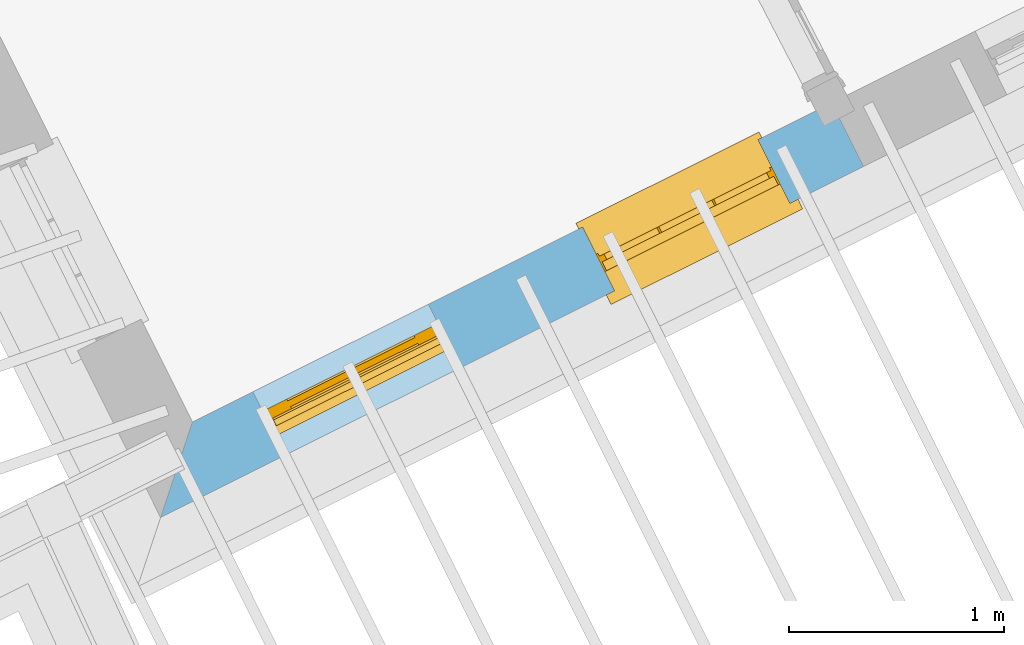
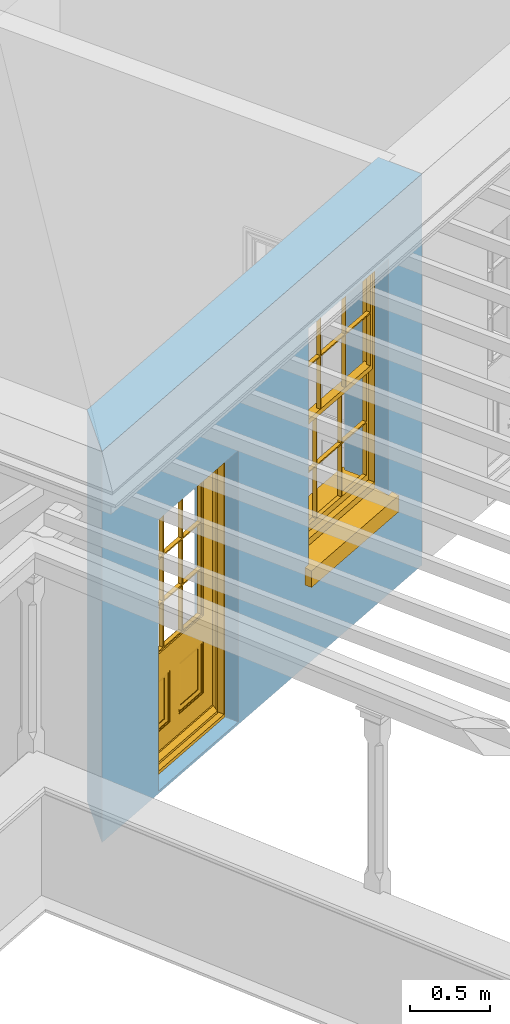
# One storey, part 2 of 7: 1 door, 1 window, 2 openings, plus 1 element that does not belong to this part.
"""IFC2X3 building model written with IfcOpenShell, lengths in metres."""

from ifc_helpers import new_model, si_unit, frame, origin, place, context, subcontext, project, spatial, polyline, outline, extrude, faceted_brep, material, layer, layer_set, layer_usage, element, fill, save


model = new_model("IFC2X3")

# Units and contexts
model_context = context("Model", 3, world=origin())
body_context = subcontext(model_context, "Body", "Model", "MODEL_VIEW")
ifc_project = project(units=[si_unit("PLANEANGLEUNIT", "RADIAN"), si_unit("MASSUNIT", "GRAM", prefix="KILO"), si_unit("FORCEUNIT", "NEWTON", prefix="KILO"), si_unit("LENGTHUNIT", "METRE")], contexts=[model_context])

# Site, building, storey
site_placement = place(None, origin())
site = spatial("IfcSite", under=ifc_project, at=site_placement, CompositionType="ELEMENT")
building_placement = place(None, origin())
building = spatial("IfcBuilding", under=site, at=building_placement, Name="Building plot-8", CompositionType="ELEMENT")
storey_placement = place(None, frame((0.0, 0.0, 6.3)))
storey = spatial("IfcBuildingStorey", under=building, at=storey_placement, Name="Floor 2", CompositionType="ELEMENT", Elevation=6.3)

# Wall, openings, door, window
ifc_material = material(Name="Masonry")
ifc_layer = layer(ifc_material, 0.33, ventilated=False)
ifc_layer_set = layer_set([ifc_layer], Name="My Wall")
ifc_layer_usage = layer_usage(ifc_layer_set, "AXIS2", "NEGATIVE", 0.08)
wall_placement = place(storey_placement, origin())
wall = element("IfcWallStandardCase", 1, at=wall_placement, inside=storey, material=ifc_layer_usage, Name="exterior", context=body_context, shape_type="SweptSolid", body=[
    extrude(outline(polyline([(24.4433832878594, 13.4608989674064), (24.2955349008038, 13.0182468981183), (27.5576474990724, 14.6468363352565), (27.4102456579562, 14.9420865634283), (24.4433832878594, 13.4608989674064)])), origin(), (0.0, 0.0, 1.0), 3.0),
])
opening_1_placement = place(storey_placement, frame((0.0, 0.0, 0.0199999999999996)))
opening_1 = element("IfcOpeningElement", 2, at=opening_1_placement, cuts=wall, Name="Opening", ObjectType="Opening", context=body_context, shape_type="SweptSolid", body=[
    extrude(outline(polyline([(24.8717314260195, 13.3059094316495), (25.685906297645, 13.7123811753337), (25.5385044565287, 14.0076314035056), (24.7243295849033, 13.6011596598214), (24.8717314260195, 13.3059094316495)])), origin(), (0.0, 0.0, 1.0), 2.08),
])
opening_2_placement = place(storey_placement, frame((0.0, 0.0, 0.75)))
opening_2 = element("IfcOpeningElement", 3, at=opening_2_placement, cuts=wall, Name="Opening", ObjectType="Opening", context=body_context, shape_type="SweptSolid", body=[
    extrude(outline(polyline([(26.4016644265464, 14.0697189719792), (27.2158392981719, 14.4761907156634), (27.0684374570556, 14.7714409438353), (26.2542625854302, 14.3649692001511), (26.4016644265464, 14.0697189719792)])), origin(), (0.0, 0.0, 1.0), 1.82),
])
door_placement = place(storey_placement, frame((24.7600633645678, 13.5295838469312, 0.0199999999999996), z_axis=(0.0, 0.0, 1.0), x_axis=(0.814174871625436, 0.406471743684232, 0.0)))
door = element("IfcDoor", 4, at=door_placement, inside=storey, Name="circulation outside door", OverallHeight=2.08, OverallWidth=0.91, context=body_context, shape_type="Brep", held_by="IfcProductRepresentation", body=[
    faceted_brep([(0.545, -0.055, 0.265), (0.745, -0.055, 0.265), (0.745, -0.05, 0.265), (0.545, -0.05, 0.265), (0.745, -0.05, 0.58), (0.545, -0.05, 0.58), (0.545, -0.055, 0.58), (0.515, -0.06, 0.235), (0.775, -0.06, 0.235), (0.745, -0.055, 0.58), (0.515, -0.06, 0.61), (0.515, -0.065, 0.235), (0.775, -0.065, 0.235), (0.775, -0.06, 0.61), (0.515, -0.065, 0.61), (0.785, -0.065, 0.225), (0.505, -0.065, 0.225), (0.775, -0.065, 0.61), (0.505, -0.065, 0.62), (0.785, -0.065, 0.62), (0.505, -0.07, 0.225), (0.785, -0.07, 0.225), (0.505, -0.07, 0.62), (0.785, -0.07, 0.62), (0.883, -0.07, 0.075), (0.898, -0.07, 0.075), (0.405, -0.07, 0.62), (0.405, -0.07, 0.225), (0.027, -0.07, 0.075), (0.785, -0.07, 0.82), (0.125, -0.07, 0.82), (0.405, -0.065, 0.62), (0.405, -0.065, 0.225), (0.898, -0.07, 2.068), (0.027, -0.08, 0.075), (0.883, -0.08, 0.075), (0.125, -0.07, 0.225), (0.012, -0.07, 0.075), (0.785, -0.06, 0.82), (0.125, -0.06, 0.82), (0.125, -0.07, 0.62), (0.125, -0.065, 0.62), (0.395, -0.065, 0.61), (0.395, -0.065, 0.235), (0.125, -0.065, 0.225), (0.785, -0.07, 1.895), (0.027, -0.11, 0.045), (0.883, -0.11, 0.045), (0.558333, -0.06, 0.83), (0.351667, -0.06, 0.83), (0.125, -0.07, 1.895), (0.125, -0.06, 1.895), (0.785, -0.06, 1.895), (0.012, -0.07, 2.068), (0.135, -0.065, 0.61), (0.395, -0.06, 0.61), (0.395, -0.06, 0.235), (0.135, -0.065, 0.235), (0.027, -0.11, 0.027), (0.883, -0.11, 0.027), (0.568333, -0.06, 0.83), (0.558333, -0.03, 0.83), (0.351667, -0.03, 0.83), (0.341667, -0.06, 0.83), (0.135, -0.06, 1.185), (0.135, -0.06, 1.53), (0.775, -0.06, 1.53), (0.775, -0.06, 1.185), (0.135, -0.06, 0.61), (0.365, -0.055, 0.58), (0.365, -0.055, 0.265), (0.135, -0.06, 0.235), (0.568333, -0.06, 1.175), (0.558333, -0.06, 1.175), (0.775, -0.06, 0.83), (0.558333, -0.03, 1.175), (0.785, -0.03, 0.82), (0.125, -0.03, 0.82), (0.351667, -0.03, 1.175), (0.351667, -0.06, 1.175), (0.341667, -0.06, 1.175), (0.135, -0.06, 0.83), (0.135, -0.06, 1.175), (0.135, -0.03, 1.185), (0.135, -0.03, 1.53), (0.135, -0.06, 1.54), (0.351667, -0.06, 1.885), (0.558333, -0.06, 1.885), (0.775, -0.03, 1.53), (0.775, -0.03, 1.185), (0.775, -0.06, 1.175), (0.775, -0.06, 1.54), (0.165, -0.055, 0.58), (0.365, -0.05, 0.58), (0.365, -0.05, 0.265), (0.165, -0.055, 0.265), (0.568333, -0.03, 0.83), (0.568333, -0.03, 1.175), (0.568333, -0.06, 1.185), (0.558333, -0.06, 1.185), (0.775, -0.03, 0.83), (0.785, -0.02, 0.82), (0.125, -0.02, 0.82), (0.341667, -0.03, 0.83), (0.341667, -0.03, 1.175), (0.351667, -0.06, 1.185), (0.341667, -0.06, 1.185), (0.135, -0.03, 0.83), (0.341667, -0.03, 1.185), (0.125, -0.03, 1.895), (0.341667, -0.03, 1.53), (0.341667, -0.06, 1.53), (0.135, -0.06, 1.885), (0.341667, -0.06, 1.54), (0.341667, -0.06, 1.885), (0.558333, -0.03, 1.885), (0.351667, -0.03, 1.885), (0.568333, -0.06, 1.885), (0.785, -0.03, 1.895), (0.568333, -0.03, 1.185), (0.568333, -0.06, 1.53), (0.568333, -0.03, 1.53), (0.568333, -0.06, 1.54), (0.775, -0.06, 1.885), (0.165, -0.05, 0.58), (0.165, -0.05, 0.265), (0.775, -0.03, 1.175), (0.558333, -0.06, 1.53), (0.351667, -0.03, 1.185), (0.558333, -0.03, 1.185), (0.505, -0.02, 0.62), (0.405, -0.02, 0.62), (0.125, -0.02, 1.895), (0.785, -0.02, 1.895), (0.351667, -0.06, 1.53), (0.135, -0.03, 1.175), (0.135, -0.03, 1.54), (0.341667, -0.03, 1.54), (0.135, -0.03, 1.885), (0.351667, -0.06, 1.54), (0.558333, -0.03, 1.54), (0.558333, -0.06, 1.54), (0.351667, -0.03, 1.54), (0.775, -0.03, 1.54), (0.568333, -0.03, 1.54), (0.775, -0.03, 1.885), (0.558333, -0.03, 1.53), (0.405, -0.02, 0.225), (0.505, -0.02, 0.225), (0.125, -0.02, 0.62), (0.785, -0.02, 0.62), (0.012, -0.02, 2.068), (0.898, -0.02, 2.068), (0.351667, -0.03, 1.53), (0.341667, -0.03, 1.885), (0.568333, -0.03, 1.885), (0.405, -0.025, 0.225), (0.405, -0.025, 0.62), (0.505, -0.025, 0.62), (0.505, -0.025, 0.225), (0.898, -0.02, 0.027), (0.012, -0.02, 0.027), (0.125, -0.025, 0.62), (0.785, -0.025, 0.62), (0.395, -0.025, 0.235), (0.395, -0.025, 0.61), (0.125, -0.02, 0.225), (0.125, -0.025, 0.225), (0.515, -0.025, 0.61), (0.515, -0.025, 0.235), (0.785, -0.02, 0.225), (0.785, -0.025, 0.225), (0.135, -0.025, 0.61), (0.775, -0.025, 0.61), (0.135, -0.025, 0.235), (0.395, -0.03, 0.235), (0.395, -0.03, 0.61), (0.515, -0.03, 0.61), (0.515, -0.03, 0.235), (0.775, -0.025, 0.235), (0.135, -0.03, 0.61), (0.775, -0.03, 0.61), (0.135, -0.03, 0.235), (0.365, -0.035, 0.265), (0.365, -0.035, 0.58), (0.545, -0.035, 0.58), (0.545, -0.035, 0.265), (0.775, -0.03, 0.235), (0.165, -0.035, 0.58), (0.745, -0.035, 0.58), (0.165, -0.035, 0.265), (0.365, -0.04, 0.58), (0.365, -0.04, 0.265), (0.545, -0.04, 0.58), (0.545, -0.04, 0.265), (0.745, -0.035, 0.265), (0.165, -0.04, 0.58), (0.745, -0.04, 0.58), (0.165, -0.04, 0.265), (0.745, -0.04, 0.265), (0.885, -0.072, 0.025), (0.025, -0.072, 0.025), (0.025, -0.1, 0.025), (0.885, -0.1, 0.025), (0.9, -0.02, 0.025), (0.01, -0.02, 0.025), (0.9, -0.072, 0.025), (0.91, -0.02, 0.0), (0.0, -0.02, 0.0), (0.01, -0.072, 0.025), (0.9, -0.072, 2.07), (0.9, -0.02, 2.07), (0.885, -0.072, 2.055), (0.91, -0.02, 2.08), (0.01, -0.02, 2.07), (0.0, -0.02, 2.08), (0.01, -0.072, 2.07), (0.025, -0.072, 2.055), (0.0, -0.15, 2.08), (0.91, -0.15, 2.08), (0.01, -0.15, 2.07), (0.9, -0.15, 2.07), (0.01, -0.1, 2.07), (0.9, -0.1, 2.07), (0.0, -0.15, 0.0), (0.91, -0.15, 0.0), (0.01, -0.15, 0.025), (0.9, -0.15, 0.025), (0.01, -0.1, 0.025), (0.025, -0.1, 2.055), (0.9, -0.1, 0.025), (0.885, -0.1, 2.055), (0.898, -0.07, 0.027), (0.012, -0.07, 0.027), (0.883, -0.07, 0.027), (0.027, -0.07, 0.027)], [[[0, 1, 2, 3]], [[2, 4, 5, 3]], [[0, 3, 5, 6]], [[1, 0, 7, 8]], [[9, 4, 2, 1]], [[9, 6, 5, 4]], [[0, 6, 10, 7]], [[8, 7, 11, 12]], [[8, 13, 9, 1]], [[13, 10, 6, 9]], [[7, 10, 14, 11]], [[15, 12, 11, 16]], [[12, 17, 13, 8]], [[17, 14, 10, 13]], [[18, 16, 11, 14]], [[15, 19, 17, 12]], [[15, 16, 20, 21]], [[14, 17, 19, 18]], [[16, 18, 22, 20]], [[21, 23, 19, 15]], [[24, 25, 21, 20]], [[23, 22, 18, 19]], [[20, 22, 26, 27]], [[23, 21, 25]], [[28, 24, 20, 27]], [[22, 23, 29]], [[29, 30, 26, 22]], [[27, 26, 31, 32]], [[23, 25, 33, 29]], [[34, 35, 24, 28]], [[28, 27, 36, 37]], [[38, 39, 30, 29]], [[26, 30, 40]], [[26, 40, 41, 31]], [[42, 43, 32, 31]], [[32, 44, 36, 27]], [[33, 45, 29]], [[46, 47, 35, 34]], [[36, 40, 37]], [[39, 38, 48, 49]], [[50, 30, 39, 51]], [[29, 45, 52, 38]], [[53, 37, 40, 30]], [[44, 41, 40, 36]], [[31, 41, 54, 42]], [[43, 42, 55, 56]], [[57, 44, 32, 43]], [[50, 45, 33, 53]], [[47, 46, 58, 59]], [[60, 48, 38]], [[49, 48, 61, 62]], [[49, 63, 39]], [[50, 53, 30]], [[51, 39, 64, 65]], [[45, 50, 51, 52]], [[66, 67, 38, 52]], [[57, 54, 41, 44]], [[42, 54, 68, 55]], [[56, 55, 69, 70]], [[56, 71, 57, 43]], [[60, 72, 73, 48]], [[60, 38, 74]], [[48, 73, 75, 61]], [[76, 77, 62, 61]], [[62, 78, 79, 49]], [[49, 79, 80, 63]], [[63, 81, 39]], [[82, 64, 39]], [[65, 64, 83, 84]], [[85, 51, 65]], [[52, 51, 86, 87]], [[88, 89, 67, 66]], [[90, 38, 67]], [[91, 66, 52]], [[71, 68, 54, 57]], [[55, 68, 92, 69]], [[69, 93, 94, 70]], [[70, 95, 71, 56]], [[96, 97, 72, 60]], [[73, 72, 98, 99]], [[74, 38, 90]], [[100, 96, 60, 74]], [[75, 73, 79, 78]], [[61, 75, 97, 96]], [[101, 102, 77, 76]], [[77, 103, 62]], [[96, 76, 61]], [[103, 104, 78, 62]], [[80, 79, 105, 106]], [[63, 80, 104, 103]], [[81, 63, 103, 107]], [[81, 82, 39]], [[106, 64, 82, 80]], [[106, 108, 83, 64]], [[84, 83, 77, 109]], [[110, 111, 65, 84]], [[112, 51, 85]], [[113, 85, 65, 111]], [[114, 86, 51]], [[115, 87, 86, 116]], [[117, 52, 87]], [[118, 76, 89, 88]], [[119, 98, 67, 89]], [[120, 121, 88, 66]], [[67, 98, 72, 90]], [[91, 122, 120, 66]], [[91, 52, 123]], [[95, 92, 68, 71]], [[69, 92, 124, 93]], [[94, 93, 124, 125]], [[94, 125, 95, 70]], [[72, 97, 126, 90]], [[127, 99, 98, 120]], [[99, 105, 79, 73]], [[74, 90, 126, 100]], [[96, 100, 76]], [[128, 129, 75, 78]], [[97, 75, 129, 119]], [[130, 131, 102, 101]], [[109, 77, 102, 132]], [[133, 101, 76, 118]], [[77, 107, 103]], [[78, 104, 108, 128]], [[111, 106, 105, 134]], [[104, 80, 82, 135]], [[107, 135, 82, 81]], [[110, 108, 106, 111]], [[104, 135, 83, 108]], [[83, 135, 77]], [[136, 84, 109]], [[110, 84, 136, 137]], [[114, 51, 112]], [[85, 136, 138, 112]], [[113, 137, 136, 85]], [[111, 134, 139, 113]], [[86, 114, 113, 139]], [[140, 141, 87, 115]], [[139, 142, 116, 86]], [[109, 118, 115, 116]], [[117, 123, 52]], [[117, 87, 141, 122]], [[126, 89, 76]], [[143, 118, 88]], [[120, 98, 119, 121]], [[119, 89, 126, 97]], [[144, 143, 88, 121]], [[144, 122, 91, 143]], [[127, 120, 122, 141]], [[143, 91, 123, 145]], [[124, 92, 95, 125]], [[146, 129, 99, 127]], [[99, 129, 128, 105]], [[100, 126, 76]], [[121, 119, 129, 146]], [[147, 131, 130, 148]], [[131, 149, 102]], [[130, 101, 150]], [[102, 151, 132]], [[118, 109, 132, 133]], [[101, 133, 152]], [[107, 77, 135]], [[153, 128, 108, 110]], [[134, 105, 128, 153]], [[109, 138, 136]], [[153, 110, 137, 142]], [[154, 114, 112, 138]], [[137, 113, 114, 154]], [[141, 139, 134, 127]], [[141, 140, 142, 139]], [[144, 140, 115, 155]], [[142, 137, 154, 116]], [[155, 115, 118]], [[116, 154, 109]], [[117, 155, 145, 123]], [[122, 144, 155, 117]], [[143, 145, 118]], [[121, 146, 140, 144]], [[146, 127, 134, 153]], [[156, 157, 131, 147]], [[148, 130, 158, 159]], [[148, 160, 161, 147]], [[157, 162, 149, 131]], [[161, 151, 102, 149]], [[101, 152, 160, 150]], [[163, 158, 130, 150]], [[151, 152, 133, 132]], [[154, 138, 109]], [[142, 140, 146, 153]], [[145, 155, 118]], [[157, 156, 164, 165]], [[147, 166, 167, 156]], [[168, 169, 159, 158]], [[170, 148, 159, 171]], [[148, 170, 160]], [[166, 147, 161]], [[172, 162, 157, 165]], [[166, 149, 162, 167]], [[166, 161, 149]], [[150, 160, 170]], [[163, 173, 168, 158]], [[171, 163, 150, 170]], [[174, 164, 156, 167]], [[175, 176, 165, 164]], [[169, 168, 177, 178]], [[171, 159, 169, 179]], [[167, 162, 172, 174]], [[176, 180, 172, 165]], [[179, 173, 163, 171]], [[181, 177, 168, 173]], [[164, 174, 182, 175]], [[183, 184, 176, 175]], [[178, 177, 185, 186]], [[179, 169, 178, 187]], [[174, 172, 180, 182]], [[184, 188, 180, 176]], [[187, 181, 173, 179]], [[189, 185, 177, 181]], [[175, 182, 190, 183]], [[191, 184, 183, 192]], [[185, 193, 194, 186]], [[187, 178, 186, 195]], [[182, 180, 188, 190]], [[191, 196, 188, 184]], [[195, 189, 181, 187]], [[197, 193, 185, 189]], [[183, 190, 198, 192]], [[198, 196, 191, 192]], [[194, 193, 197, 199]], [[195, 186, 194, 199]], [[188, 196, 198, 190]], [[197, 189, 195, 199]], [[200, 201, 202, 203]], [[201, 200, 204, 205]], [[206, 204, 200]], [[204, 207, 208, 205]], [[209, 201, 205]], [[210, 211, 204, 206]], [[206, 200, 212, 210]], [[211, 213, 207, 204]], [[214, 205, 208, 215]], [[216, 217, 201, 209]], [[205, 214, 216, 209]], [[216, 214, 211, 210]], [[210, 212, 217, 216]], [[214, 215, 213, 211]], [[218, 219, 213, 215]], [[219, 218, 220, 221]], [[221, 220, 222, 223]], [[215, 208, 224, 218]], [[225, 224, 208, 207]], [[224, 226, 220, 218]], [[224, 225, 227, 226]], [[219, 225, 207, 213]], [[228, 222, 220, 226]], [[219, 221, 227, 225]], [[226, 227, 203, 202]], [[202, 229, 222, 228]], [[228, 226, 202]], [[227, 221, 223, 230]], [[230, 203, 227]], [[217, 229, 202, 201]], [[231, 223, 222, 229]], [[230, 223, 231, 203]], [[231, 229, 217, 212]], [[212, 200, 203, 231]], [[33, 152, 151, 53]], [[25, 160, 152, 33]], [[161, 37, 53, 151]], [[232, 160, 25]], [[161, 233, 37]], [[160, 232, 234]], [[24, 234, 232, 25]], [[233, 161, 235]], [[37, 233, 235, 28]], [[161, 160, 234, 235]], [[35, 47, 234, 24]], [[28, 235, 46, 34]], [[58, 235, 234, 59]], [[59, 234, 47]], [[58, 46, 235]]]),
])
fill(opening_1, door)
window_placement = place(storey_placement, frame((26.2899963650947, 14.2933933872609, 0.75), z_axis=(0.0, 0.0, 1.0), x_axis=(0.81417487162544, 0.406471743684232, 0.0)))
window = element("IfcWindow", 5, at=window_placement, inside=storey, Name="circulation outside window", OverallHeight=1.82, OverallWidth=0.91, context=body_context, shape_type="Brep", held_by="IfcProductRepresentation", body=[
    faceted_brep([(0.033125, -0.105, 0.975209), (0.01, -0.105, 0.975209), (0.033125, -0.105, 1.376042), (0.876875, -0.105, 0.975209), (0.876875, -0.105, 1.376042), (0.9, -0.105, 0.975209), (0.876875, -0.105, 1.386042), (0.876875, -0.105, 1.786875), (0.9, -0.105, 1.81), (0.033125, -0.105, 1.786875), (0.033125, -0.105, 1.386042), (0.01, -0.105, 1.81), (0.876875, -0.135, 1.376042), (0.876875, -0.135, 0.975209), (0.9, -0.135, 0.937083), (0.033125, -0.135, 1.786875), (0.01, -0.135, 1.81), (0.033125, -0.135, 1.386042), (0.01, -0.135, 0.937083), (0.033125, -0.135, 0.975209), (0.033125, -0.135, 1.376042), (0.876875, -0.135, 1.786875), (0.876875, -0.135, 1.386042), (0.9, -0.135, 1.81), (0.033125, -0.105, 0.937083), (0.01, -0.105, 0.937083), (0.033125, -0.105, 0.53625), (0.876875, -0.105, 0.937083), (0.876875, -0.105, 0.53625), (0.9, -0.105, 0.937083), (0.876875, -0.105, 0.52625), (0.876875, -0.105, 0.125417), (0.9, -0.105, 0.077167), (0.033125, -0.105, 0.125417), (0.033125, -0.105, 0.52625), (0.01, -0.105, 0.077167), (-0.0425, -0.25, 0.01), (-0.0425, -0.3, 0.001667), (0.0, -0.25, 0.01), (0.9525, -0.25, 0.01), (0.91, -0.25, 0.01), (0.9525, -0.3, 0.001667), (-0.02, 0.08, 0.077167), (0.0, 0.08, 0.077167), (-0.02, 0.11, 0.077167), (0.0, -0.06, 0.077167), (0.01, -0.06, 0.077167), (0.91, -0.06, 0.077167), (0.91, 0.08, 0.077167), (0.9, -0.06, 0.077167), (0.93, 0.08, 0.077167), (0.93, 0.11, 0.077167), (0.01, -0.075, 0.975209), (0.9, -0.075, 0.975209), (0.876875, -0.075, 0.125417), (0.876875, -0.075, 0.52625), (0.9, -0.075, 0.077167), (0.876875, -0.075, 0.53625), (0.876875, -0.075, 0.937083), (0.033125, -0.075, 0.125417), (0.01, -0.075, 0.077167), (0.033125, -0.075, 0.52625), (0.033125, -0.075, 0.937083), (0.033125, -0.075, 0.53625), (-0.02, 0.08, 0.052167), (-0.02, 0.11, 0.052167), (0.93, 0.11, 0.052167), (0.93, 0.08, 0.052167), (0.91, 0.08, 0.052167), (0.0, 0.08, 0.052167), (0.91, -0.15, 0.026667), (0.0, -0.15, 0.026667), (-0.0425, -0.3, -0.123333), (0.9525, -0.3, -0.123333), (-0.0425, -0.25, -0.123333), (0.9525, -0.25, -0.123333), (0.01, -0.06, 1.81), (0.9, -0.06, 1.81), (0.0, -0.06, 1.82), (0.91, -0.06, 1.82), (0.01, -0.15, 0.077167), (0.9, -0.15, 0.077167), (0.592292, -0.105, 0.125417), (0.592292, -0.075, 0.125417), (0.317708, -0.075, 0.125417), (0.317708, -0.105, 0.125417), (0.592292, -0.105, 0.53625), (0.317708, -0.105, 0.53625), (0.317708, -0.105, 0.52625), (0.592292, -0.105, 0.52625), (0.592292, -0.075, 0.53625), (0.317708, -0.075, 0.53625), (0.592292, -0.135, 1.386042), (0.592292, -0.105, 1.386042), (0.317708, -0.105, 1.386042), (0.317708, -0.135, 1.386042), (0.317708, -0.135, 1.376042), (0.592292, -0.135, 1.376042), (0.317708, -0.105, 1.376042), (0.592292, -0.105, 1.376042), (0.602292, -0.135, 1.376042), (0.592292, -0.135, 0.975209), (0.602292, -0.135, 0.975209), (0.602292, -0.105, 0.975209), (0.592292, -0.105, 0.975209), (0.602292, -0.105, 1.376042), (0.602292, -0.075, 0.53625), (0.602292, -0.105, 0.53625), (0.317708, -0.075, 0.52625), (0.307708, -0.075, 0.125417), (0.307708, -0.075, 0.52625), (0.602292, -0.075, 0.52625), (0.602292, -0.075, 0.125417), (0.592292, -0.075, 0.52625), (0.307708, -0.075, 0.53625), (0.317708, -0.075, 0.937083), (0.307708, -0.075, 0.937083), (0.602292, -0.075, 0.937083), (0.592292, -0.075, 0.937083), (0.307708, -0.105, 0.52625), (0.307708, -0.105, 0.125417), (0.307708, -0.105, 0.53625), (0.307708, -0.105, 0.937083), (0.592292, -0.105, 0.937083), (0.317708, -0.105, 0.937083), (0.602292, -0.105, 0.937083), (0.602292, -0.105, 0.52625), (0.602292, -0.105, 0.125417), (0.307708, -0.135, 1.386042), (0.307708, -0.135, 1.376042), (0.307708, -0.135, 0.975209), (0.317708, -0.135, 0.975209), (0.317708, -0.135, 1.786875), (0.307708, -0.135, 1.786875), (0.602292, -0.135, 1.786875), (0.592292, -0.135, 1.786875), (0.602292, -0.135, 1.386042), (0.602292, -0.105, 1.386042), (0.307708, -0.105, 1.386042), (0.307708, -0.105, 1.786875), (0.317708, -0.105, 1.786875), (0.592292, -0.105, 1.786875), (0.602292, -0.105, 1.786875), (0.307708, -0.105, 1.376042), (0.317708, -0.105, 0.975209), (0.307708, -0.105, 0.975209), (0.91, -0.15, 1.82), (0.9, -0.15, 1.81), (0.01, -0.15, 1.81), (0.0, -0.15, 1.82), (0.91, -0.25, 0.0), (0.0, -0.25, 0.0), (0.91, 0.08, 0.0), (0.0, 0.08, 0.0)], [[[0, 1, 2]], [[3, 4, 5]], [[6, 7, 8]], [[9, 10, 11]], [[12, 13, 14]], [[15, 16, 17]], [[18, 19, 20]], [[21, 22, 23]], [[24, 25, 26]], [[27, 28, 29]], [[30, 31, 32]], [[33, 34, 35]], [[14, 27, 29]], [[25, 24, 18]], [[36, 37, 38]], [[39, 40, 41]], [[42, 43, 44]], [[45, 46, 43]], [[47, 48, 49]], [[50, 51, 48]], [[1, 0, 52]], [[5, 53, 3]], [[54, 55, 56]], [[57, 58, 53]], [[59, 60, 61]], [[62, 63, 52]], [[48, 43, 46, 49]], [[51, 44, 43, 48]], [[64, 42, 44, 65]], [[65, 44, 51, 66]], [[66, 51, 50, 67]], [[65, 66, 68, 69]], [[60, 56, 49, 46]], [[70, 71, 38, 40]], [[37, 41, 40, 38]], [[37, 72, 73, 41]], [[74, 75, 73, 72]], [[8, 11, 76, 77]], [[76, 78, 79, 77]], [[32, 35, 80, 81]], [[81, 80, 71, 70]], [[82, 83, 84, 85]], [[86, 87, 88, 89]], [[86, 90, 91, 87]], [[92, 93, 94, 95]], [[92, 95, 96, 97]], [[96, 98, 99, 97]], [[100, 97, 101, 102]], [[103, 104, 99, 105]], [[97, 99, 104, 101]], [[102, 103, 105, 100]], [[28, 57, 106, 107]], [[108, 84, 109, 110]], [[111, 112, 83, 113]], [[114, 110, 61, 63]], [[90, 113, 108, 91]], [[115, 91, 114, 116]], [[117, 106, 90, 118]], [[111, 106, 57, 55]], [[119, 110, 109, 120]], [[34, 61, 110, 119]], [[89, 113, 83, 82]], [[88, 108, 113, 89]], [[85, 84, 108, 88]], [[121, 114, 63, 26]], [[122, 116, 114, 121]], [[123, 118, 90, 86]], [[87, 91, 115, 124]], [[107, 106, 117, 125]], [[126, 111, 55, 30]], [[127, 112, 111, 126]], [[126, 30, 28, 107]], [[88, 119, 120, 85]], [[126, 89, 82, 127]], [[125, 123, 86, 107]], [[121, 26, 34, 119]], [[124, 122, 121, 87]], [[128, 17, 20, 129]], [[96, 129, 130, 131]], [[132, 133, 128, 95]], [[134, 135, 92, 136]], [[100, 12, 22, 136]], [[137, 6, 4, 105]], [[94, 138, 139, 140]], [[137, 93, 141, 142]], [[99, 98, 94, 93]], [[143, 2, 10, 138]], [[144, 145, 143, 98]], [[129, 143, 145, 130]], [[20, 2, 143, 129]], [[131, 144, 98, 96]], [[128, 138, 10, 17]], [[133, 139, 138, 128]], [[135, 141, 93, 92]], [[95, 94, 140, 132]], [[22, 6, 137, 136]], [[136, 137, 142, 134]], [[100, 105, 4, 12]], [[107, 86, 89, 126]], [[106, 111, 113, 90]], [[91, 108, 110, 114]], [[87, 121, 119, 88]], [[97, 100, 136, 92]], [[129, 96, 95, 128]], [[98, 143, 138, 94]], [[105, 99, 93, 137]], [[131, 101, 104, 144]], [[124, 115, 118, 123]], [[132, 140, 141, 135]], [[120, 109, 59, 33]], [[15, 9, 139, 133]], [[134, 142, 7, 21]], [[31, 54, 112, 127]], [[36, 74, 72, 37]], [[39, 41, 73, 75]], [[18, 14, 101, 131]], [[23, 16, 132, 135]], [[83, 56, 60, 84]], [[52, 53, 118, 115]], [[53, 52, 144, 104]], [[11, 8, 141, 140]], [[14, 18, 124, 123]], [[2, 1, 11, 10]], [[8, 5, 4, 6]], [[57, 53, 56, 55]], [[60, 52, 63, 61]], [[26, 25, 35, 34]], [[32, 29, 28, 30]], [[14, 23, 22, 12]], [[18, 20, 17, 16]], [[19, 0, 2, 20]], [[17, 10, 9, 15]], [[12, 4, 3, 13]], [[21, 7, 6, 22]], [[27, 58, 57, 28]], [[30, 55, 54, 31]], [[33, 59, 61, 34]], [[26, 63, 62, 24]], [[5, 8, 77, 53]], [[76, 11, 1, 52]], [[46, 45, 78, 76]], [[49, 77, 79, 47]], [[70, 146, 147, 81]], [[71, 80, 148, 149]], [[19, 130, 145, 0]], [[102, 13, 3, 103]], [[116, 122, 24, 62]], [[29, 32, 81, 14]], [[80, 35, 25, 18]], [[60, 46, 76, 52]], [[77, 49, 56, 53]], [[23, 14, 81, 147]], [[16, 148, 80, 18]], [[35, 85, 120]], [[120, 33, 35]], [[127, 82, 32]], [[32, 31, 127]], [[32, 82, 85, 35]], [[102, 101, 14]], [[14, 13, 102]], [[18, 131, 130]], [[130, 19, 18]], [[134, 21, 23]], [[23, 135, 134]], [[16, 15, 133]], [[133, 132, 16]], [[11, 140, 139]], [[139, 9, 11]], [[142, 141, 8]], [[8, 7, 142]], [[23, 147, 148, 16]], [[146, 149, 148, 147]], [[52, 115, 116]], [[116, 62, 52]], [[118, 53, 117]], [[58, 117, 53]], [[27, 125, 117, 58]], [[56, 83, 112]], [[112, 54, 56]], [[109, 84, 60]], [[60, 59, 109]], [[125, 27, 14]], [[14, 123, 125]], [[122, 124, 18]], [[18, 24, 122]], [[145, 144, 52]], [[52, 0, 145]], [[103, 3, 53]], [[53, 104, 103]], [[79, 78, 149, 146]], [[78, 45, 71, 149]], [[146, 70, 47, 79]], [[150, 75, 74, 151]], [[68, 66, 67]], [[48, 68, 67, 50]], [[69, 64, 65]], [[42, 64, 69, 43]], [[69, 68, 152, 153]], [[70, 68, 48, 47]], [[150, 152, 68, 70]], [[43, 69, 71, 45]], [[69, 153, 151, 71]], [[152, 150, 151, 153]], [[38, 151, 74, 36]], [[71, 151, 38]], [[39, 75, 150, 40]], [[40, 150, 70]]]),
])
fill(opening_2, window)

save(model, "model.ifc")
